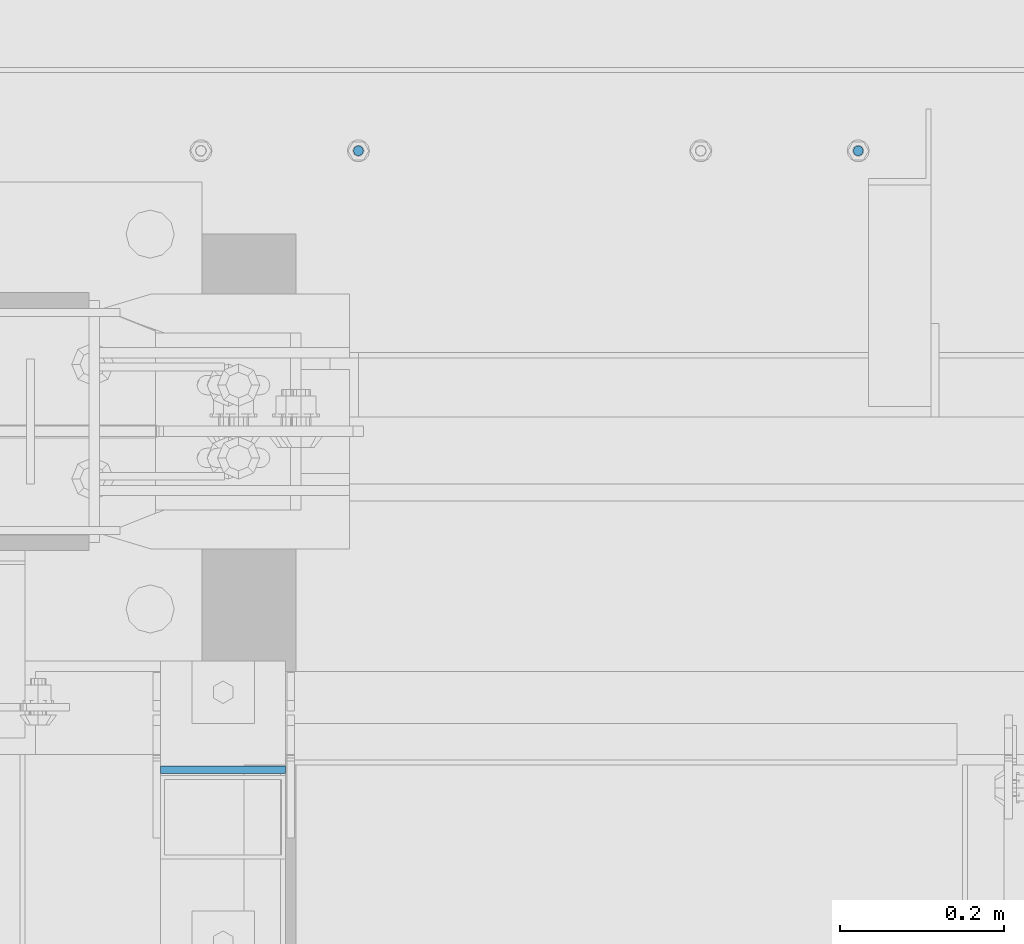
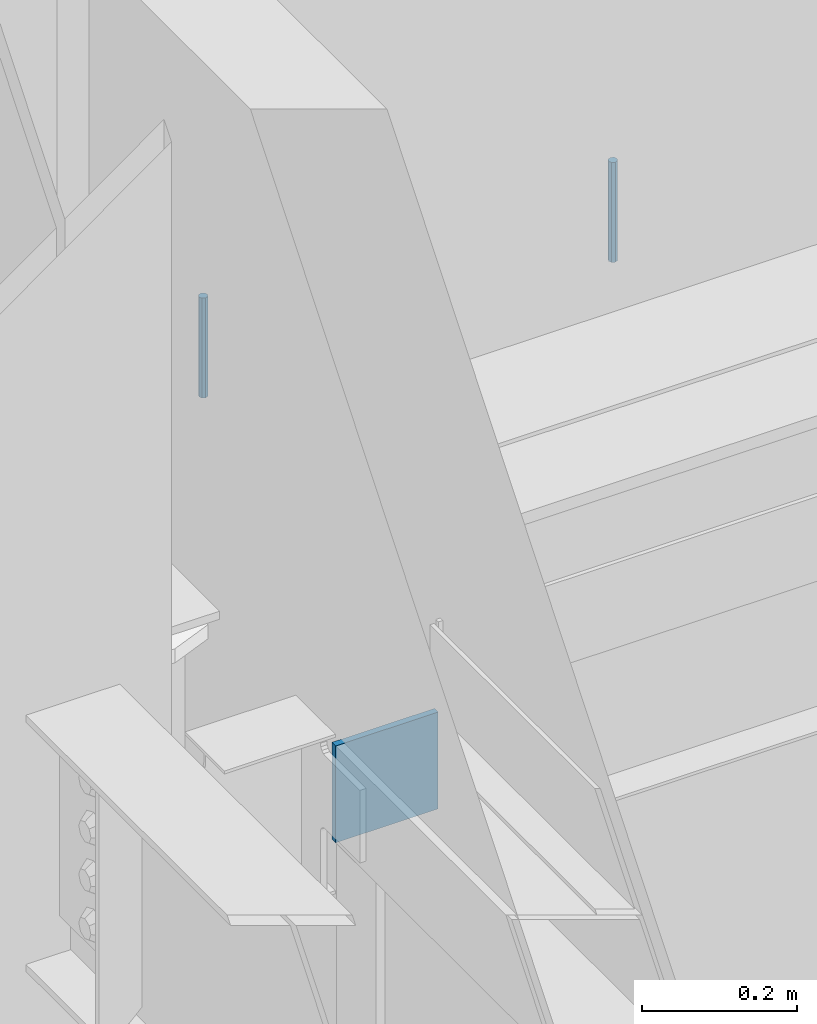
# One storey, part 592 of 1179: 3 columns, 2 elements without a shape of their own.
"""IFC2X3 building model written with IfcOpenShell, lengths in millimetres."""

from ifc_helpers import new_model, si_unit, frame, origin_with_axes, place, context, subcontext, project, spatial, faceted_brep, material, type_object, element, aggregate, save


model = new_model("IFC2X3")

# Units and contexts
model_context = context("Model", 3, precision=1e-05, world=origin_with_axes())
body_context = subcontext(model_context, "Body", "Model", "MODEL_VIEW")
ifc_project = project(units=[si_unit("LENGTHUNIT", "METRE", prefix="MILLI"), si_unit("AREAUNIT", "SQUARE_METRE"), si_unit("VOLUMEUNIT", "CUBIC_METRE"), si_unit("MASSUNIT", "GRAM", prefix="KILO"), si_unit("TIMEUNIT", "SECOND"), si_unit("PLANEANGLEUNIT", "RADIAN"), si_unit("SOLIDANGLEUNIT", "STERADIAN"), si_unit("THERMODYNAMICTEMPERATUREUNIT", "DEGREE_CELSIUS"), si_unit("LUMINOUSINTENSITYUNIT", "LUMEN")], contexts=[model_context])

# Site, building, storey
site_placement = place(None, origin_with_axes())
site = spatial("IfcSite", under=ifc_project, at=site_placement, CompositionType="ELEMENT")
building_placement = place(site_placement, origin_with_axes())
building = spatial("IfcBuilding", under=site, at=building_placement, Name="Undefined", CompositionType="ELEMENT")
storey_placement = place(building_placement, origin_with_axes())
storey = spatial("IfcBuildingStorey", under=building, at=storey_placement, Name="Undefined", CompositionType="ELEMENT", Elevation=0.0)

# Assembly, columns
assembly_1_placement = place(storey_placement, origin_with_axes())
assembly_1 = element("IfcElementAssembly", 1, at=assembly_1_placement, inside=storey, Name="BEAM", AssemblyPlace="NOTDEFINED", PredefinedType="RIGID_FRAME")
ifc_material_1 = material(Name="STEEL/A307")
column_type_1 = type_object("IfcColumnType", PredefinedType="NOTDEFINED")
column_1_placement = place(assembly_1_placement, frame((17551.4, 41529.0, 13125.45), z_axis=(0.0, 1.0, 0.0), x_axis=(0.0, 0.0, 1.0)))
column_1 = element("IfcColumn", 2, at=column_1_placement, type_object=column_type_1, material=ifc_material_1, Name="THREADED ROD", context=body_context, shape_type="Brep", body=[
    faceted_brep([(0.0, -6.34999999999854, 0.0), (0.0, -4.49012806053361, -4.49012806053452), (157.162499999999, -4.49012806053361, -4.49012806053361), (157.162499999999, -6.34999999999854, 0.0), (0.0, 0.0, -6.34999999999991), (157.162499999999, 0.0, -6.34999999999854), (0.0, 4.49012806053361, -4.49012806053452), (157.162499999999, 4.49012806053361, -4.49012806053361), (0.0, 6.34999999999854, 0.0), (157.162499999999, 6.34999999999854, 0.0), (0.0, 4.49012806053361, 4.49012806053452), (157.162499999999, 4.49012806053361, 4.49012806053361), (0.0, 0.0, 6.34999999999991), (157.162499999999, 0.0, 6.34999999999854), (0.0, -4.49012806053361, 4.49012806053452), (157.162499999999, -4.49012806053361, 4.49012806053361)], [[[0, 1, 2, 3]], [[1, 4, 5, 2]], [[4, 6, 7, 5]], [[6, 8, 9, 7]], [[8, 10, 11, 9]], [[10, 12, 13, 11]], [[12, 14, 15, 13]], [[14, 0, 3, 15]], [[5, 7, 9, 11, 13, 15, 3, 2]], [[14, 12, 10, 8, 6, 4, 1, 0]]]),
])
column_2_placement = place(assembly_1_placement, frame((16941.8, 41529.0, 13125.45), z_axis=(0.0, 1.0, 0.0), x_axis=(0.0, 0.0, 1.0)))
column_2 = element("IfcColumn", 3, at=column_2_placement, type_object=column_type_1, material=ifc_material_1, Name="THREADED ROD", context=body_context, shape_type="Brep", body=[
    faceted_brep([(0.0, -6.34999999999854, 0.0), (0.0, -4.49012806053361, -4.49012806053452), (157.162499999999, -4.49012806053361, -4.49012806053361), (157.162499999999, -6.34999999999854, 0.0), (0.0, 0.0, -6.34999999999991), (157.162499999999, 0.0, -6.34999999999854), (0.0, 4.49012806053361, -4.49012806053452), (157.162499999999, 4.49012806053361, -4.49012806053361), (0.0, 6.34999999999854, 0.0), (157.162499999999, 6.34999999999854, 0.0), (0.0, 4.49012806053361, 4.49012806053452), (157.162499999999, 4.49012806053361, 4.49012806053361), (0.0, 0.0, 6.34999999999991), (157.162499999999, 0.0, 6.34999999999854), (0.0, -4.49012806053361, 4.49012806053452), (157.162499999999, -4.49012806053361, 4.49012806053361)], [[[0, 1, 2, 3]], [[1, 4, 5, 2]], [[4, 6, 7, 5]], [[6, 8, 9, 7]], [[8, 10, 11, 9]], [[10, 12, 13, 11]], [[12, 14, 15, 13]], [[14, 0, 3, 15]], [[5, 7, 9, 11, 13, 15, 3, 2]], [[14, 12, 10, 8, 6, 4, 1, 0]]]),
])
aggregate(assembly_1, [column_1, column_2])

# Assembly, column
assembly_2_placement = place(storey_placement, origin_with_axes())
assembly_2 = element("IfcElementAssembly", 4, at=assembly_2_placement, inside=storey, Name="BEAM", AssemblyPlace="NOTDEFINED", PredefinedType="RIGID_FRAME")
ifc_material_2 = material(Name="STEEL/A36")
column_type_2 = type_object("IfcColumnType", PredefinedType="NOTDEFINED")
column_3_placement = place(assembly_2_placement, frame((16776.7, 40774.1755, 12966.7), z_axis=(-1.0, 0.0, 0.0), x_axis=(0.0, 0.0, 1.0)))
column_3 = element("IfcColumn", 5, at=column_3_placement, type_object=column_type_2, material=ifc_material_2, Name="PLATE", context=body_context, shape_type="Brep", body=[
    faceted_brep([(0.0, 4.76249999999982, -76.1999999999971), (0.0, 4.76249999999982, 76.1999999999971), (152.4, 4.76249999999709, 76.2), (152.4, 4.76249999999709, -76.2), (0.0, -4.76249999999982, 76.1999999999971), (152.4, -4.76249999999709, 76.2), (0.0, -4.76249999999982, -76.1999999999971), (152.4, -4.76249999999709, -76.2)], [[[0, 1, 2, 3]], [[1, 4, 5, 2]], [[4, 6, 7, 5]], [[6, 0, 3, 7]], [[5, 7, 3, 2]], [[6, 4, 1, 0]]]),
])
aggregate(assembly_2, [column_3])

save(model, "model.ifc")
